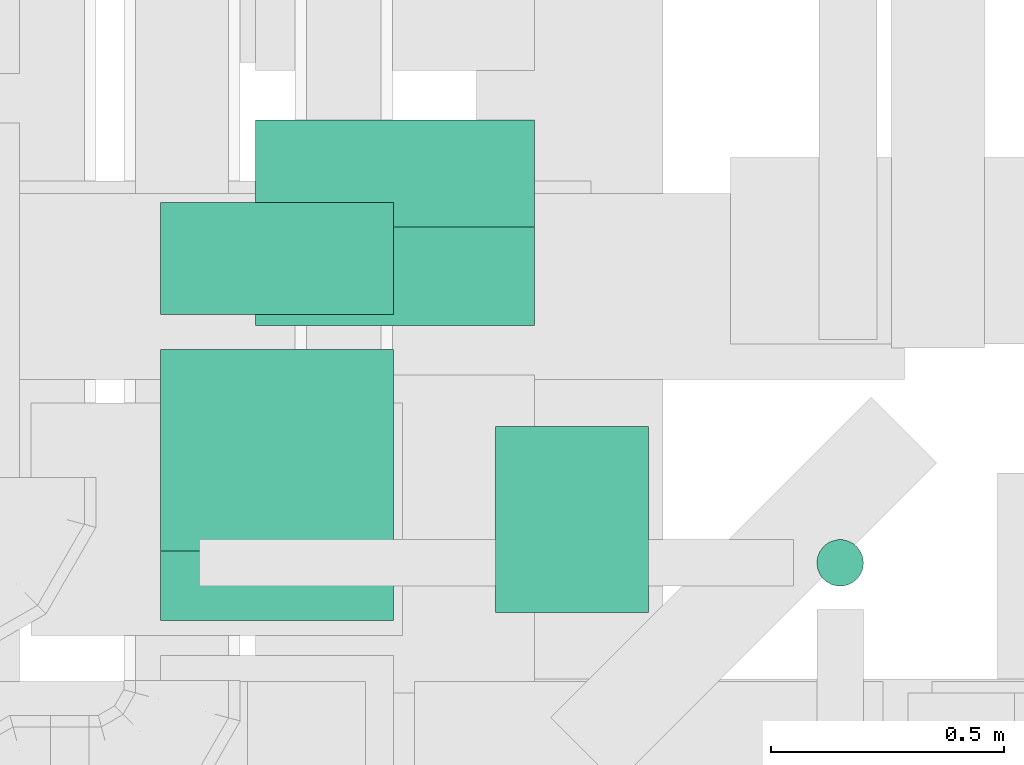
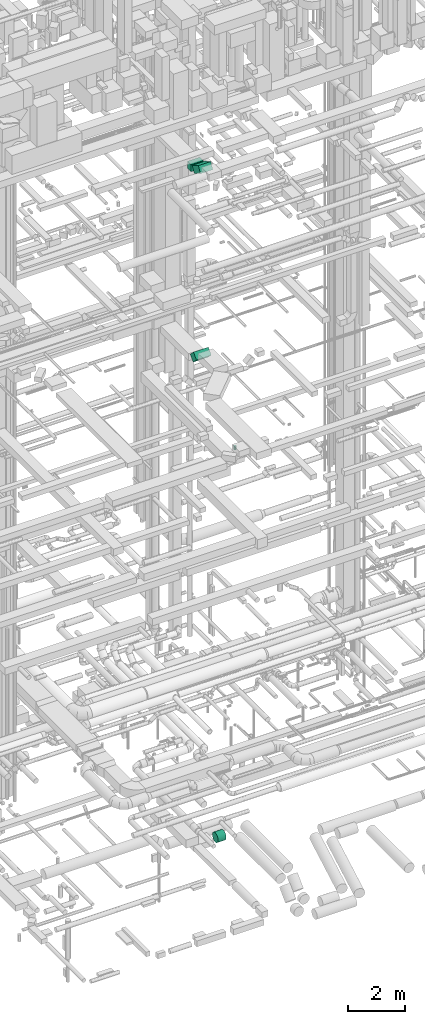
# One storey, part 168 of 337: 5 flow segments.
"""IFC2X3 building model written with IfcOpenShell, lengths in millimetres."""

import ifcopenshell
import ifcopenshell.guid

model = None  # the IFC model being written
_history = None  # IfcOwnerHistory: only IFC2X3 demands one
_inside = {}  # id of a spatial element -> (the spatial element, [elements in it])
_under = {}  # id of a project, library or spatial element -> (it, [spatial elements below it])
_declared = {}  # id of a project -> (the project, [libraries it declares])
_typed = {}  # id of a type object -> (the type object, [elements of that type])
_made_of = {}  # id of a material, layer set ... -> (it, [elements and type objects made of it])


def new_model(schema):
    """Start an empty IFC model of exactly this schema.

    Asked for "IFC4X3", IfcOpenShell would pick the latest addendum, in which some entities
    have other attributes; the version numbers below select the first issue.
    IFC2X3 requires an IfcOwnerHistory on every rooted entity: one is made here for all.
    """
    global model, _history
    if schema == "IFC4X3":
        model = ifcopenshell.file(schema_version=(4, 3, 0, 0))
    else:
        model = ifcopenshell.file(schema=schema)
    _inside.clear()
    _under.clear()
    _declared.clear()
    _typed.clear()
    _made_of.clear()
    _history = None
    if model.schema == "IFC2X3":
        org = make("IfcOrganization", Name="unknown")
        user = make(
            "IfcPersonAndOrganization",
            ThePerson=make("IfcPerson", FamilyName="unknown"),
            TheOrganization=org,
        )
        app = make(
            "IfcApplication",
            ApplicationDeveloper=org,
            Version="unknown",
            ApplicationFullName="unknown",
            ApplicationIdentifier="unknown",
        )
        _history = make(
            "IfcOwnerHistory",
            OwningUser=user,
            OwningApplication=app,
            ChangeAction="ADDED",
            CreationDate=0,
        )
    return model


def make(cls, **values):
    """One entity of the class cls with the attributes given. An attribute that is None is left unset."""
    return model.create_entity(
        cls, **{name: value for name, value in values.items() if value is not None}
    )


def entity(cls, *values):
    """Any entity or typed value of the class cls, its attributes in the order of the schema. None: left unset."""
    e = model.create_entity(cls)
    for i, value in enumerate(values):
        if value is not None:
            e[i] = value
    return e


def rooted(cls, **values):
    """An entity with a GlobalId (a new one), such as an element, a storey or a relation."""
    return make(cls, GlobalId=ifcopenshell.guid.new(), OwnerHistory=_history, **values)


def si_unit(unit_type, name, prefix=None):
    """IfcSIUnit, for example si_unit("LENGTHUNIT", "METRE", prefix="MILLI")."""
    return make("IfcSIUnit", UnitType=unit_type, Prefix=prefix, Name=name)


def converted_unit(unit_type, name, factor, base, dimensions=None, offset=None):
    """IfcConversionBasedUnit, such as the inch: factor (a typed value) times the base unit."""
    return make(
        "IfcConversionBasedUnit"
        if offset is None
        else "IfcConversionBasedUnitWithOffset",
        ConversionOffset=offset,
        Dimensions=None
        if dimensions is None
        else entity("IfcDimensionalExponents", *dimensions),
        UnitType=unit_type,
        Name=name,
        ConversionFactor=make(
            "IfcMeasureWithUnit", ValueComponent=factor, UnitComponent=base
        ),
    )


def derived_unit(unit_type, elements):
    """IfcDerivedUnit: a product of units, each with its exponent."""
    return make(
        "IfcDerivedUnit",
        Elements=[
            make("IfcDerivedUnitElement", Unit=unit, Exponent=power)
            for unit, power in elements
        ],
        UnitType=unit_type,
    )


def assignment(units):
    """IfcUnitAssignment: the units of a project."""
    return None if units is None else make("IfcUnitAssignment", Units=units)


def point(xyz):
    """IfcCartesianPoint."""
    return None if xyz is None else make("IfcCartesianPoint", Coordinates=xyz)


def direction(xyz):
    """IfcDirection."""
    return None if xyz is None else make("IfcDirection", DirectionRatios=xyz)


def frame(location, z_axis=None, x_axis=None):
    """IfcAxis2Placement3D, a coordinate frame: its origin and axes. An axis left out is left unset."""
    return make(
        "IfcAxis2Placement3D",
        Location=point(location),
        Axis=direction(z_axis),
        RefDirection=direction(x_axis),
    )


def frame_2d(location, x_axis=None):
    """IfcAxis2Placement2D, a coordinate frame in the plane: its origin and x axis."""
    return make(
        "IfcAxis2Placement2D", Location=point(location), RefDirection=direction(x_axis)
    )


def origin():
    """The frame at (0, 0, 0) with its axes left unset."""
    return frame((0.0, 0.0, 0.0))


def origin_2d_with_axis():
    """The frame at (0, 0) in the plane with the x axis (1, 0) written out."""
    return frame_2d((0.0, 0.0), x_axis=(1.0, 0.0))


def place(relative_to, where):
    """IfcLocalPlacement: puts the frame where relative to a parent placement (None: the world)."""
    return make(
        "IfcLocalPlacement", PlacementRelTo=relative_to, RelativePlacement=where
    )


def context(
    kind, dimensions, precision=None, world=None, true_north=None, identifier=None
):
    """IfcGeometricRepresentationContext, for example the 3D "Model" context."""
    return make(
        "IfcGeometricRepresentationContext",
        ContextIdentifier=identifier,
        ContextType=kind,
        CoordinateSpaceDimension=dimensions,
        Precision=precision,
        WorldCoordinateSystem=world,
        TrueNorth=true_north,
    )


def subcontext(parent, identifier, kind, view, scale=None):
    """IfcGeometricRepresentationSubContext, for example "Body" below "Model"."""
    return make(
        "IfcGeometricRepresentationSubContext",
        ContextIdentifier=identifier,
        ContextType=kind,
        ParentContext=parent,
        TargetScale=scale,
        TargetView=view,
    )


def project(units=None, contexts=None):
    """IfcProject with its units and contexts."""
    return rooted(
        "IfcProject",
        Name="project",
        RepresentationContexts=contexts,
        UnitsInContext=assignment(units),
    )


def spatial(cls, under=None, at=None, **own):
    """A site, building, storey or space (cls), placed at a placement, below another one or the project."""
    s = rooted(cls, ObjectPlacement=at, **own)
    if under is not None:
        _under.setdefault(under.id(), (under, []))[1].append(s)
    return s


def profile(cls, at=None, kind="AREA", **sizes):
    """A parametric profile (cls). Its sizes go by their IFC names, for example OverallWidth=200.0."""
    return make(cls, ProfileType=kind, Position=at, **sizes)


def rectangle(**sizes):
    """IfcRectangleProfileDef."""
    return profile("IfcRectangleProfileDef", **sizes)


def circle(**sizes):
    """IfcCircleProfileDef."""
    return profile("IfcCircleProfileDef", **sizes)


def extrude(swept, where, along, depth):
    """IfcExtrudedAreaSolid: the profile swept, set in the frame where, extruded along a direction by depth."""
    return make(
        "IfcExtrudedAreaSolid",
        SweptArea=swept,
        Position=where,
        ExtrudedDirection=direction(along),
        Depth=depth,
    )


def shape(context_of_items, identifier, shape_type, items):
    """IfcShapeRepresentation: the items that make up one representation, for example the "Body"."""
    return make(
        "IfcShapeRepresentation",
        ContextOfItems=context_of_items,
        RepresentationIdentifier=identifier,
        RepresentationType=shape_type,
        Items=items,
    )


def made_of(thing, what):
    """Note that an element or type object is made of a material, layer set ...; save() writes the relation."""
    if what is not None:
        _made_of.setdefault(what.id(), (what, []))[1].append(thing)
    return thing


def type_object(cls, material=None, **own):
    """A type object (cls), such as IfcWallType, which elements share."""
    return made_of(rooted(cls, **own), material)


def element(
    cls,
    number,
    at=None,
    inside=None,
    cuts=None,
    type_object=None,
    material=None,
    context=None,
    identifier="Body",
    shape_type=None,
    held_by="IfcProductDefinitionShape",
    body=None,
    shapes=None,
    **own,
):
    """One element of the class cls, such as IfcWall. Its Tag is "e" and its number.

    at: its placement. inside: the storey or other place that contains it. cuts: it is an
    opening in that element (IfcRelVoidsElement). A single representation is given by context,
    identifier, shape_type and body (its items); several are given by shapes. held_by: the class
    of the entity that holds the representations. save() writes the other relations.
    """
    e = rooted(cls, Tag="e%d" % number, ObjectPlacement=at, **own)
    if body is not None:
        shapes = [shape(context, identifier, shape_type, body)]
    if shapes is not None:
        e.Representation = make(held_by, Representations=shapes)
    if inside is not None:
        _inside.setdefault(inside.id(), (inside, []))[1].append(e)
    if cuts is not None:
        rooted(
            "IfcRelVoidsElement", RelatingBuildingElement=cuts, RelatedOpeningElement=e
        )
    if type_object is not None:
        _typed.setdefault(type_object.id(), (type_object, []))[1].append(e)
    return made_of(e, material)


def aggregate(whole, parts):
    """IfcRelAggregates: a whole, such as a stair, and the parts it consists of."""
    return rooted("IfcRelAggregates", RelatingObject=whole, RelatedObjects=parts)


def save(model, path):
    """Write the relations noted so far, then the file.

    IfcRelAggregates (storeys below a building ...), IfcRelContainedInSpatialStructure (elements
    in a storey), IfcRelDefinesByType, IfcRelAssociatesMaterial and IfcRelDeclares: one each for
    every whole, place, type object, material and project.
    """
    for whole, parts in _under.values():
        aggregate(whole, parts)
    for where, things in _inside.values():
        rooted(
            "IfcRelContainedInSpatialStructure",
            RelatedElements=things,
            RelatingStructure=where,
        )
    for kind, things in _typed.values():
        rooted("IfcRelDefinesByType", RelatedObjects=things, RelatingType=kind)
    for what, things in _made_of.values():
        rooted("IfcRelAssociatesMaterial", RelatedObjects=things, RelatingMaterial=what)
    for by, libraries in _declared.values():
        rooted("IfcRelDeclares", RelatingContext=by, RelatedDefinitions=libraries)
    model.write(path)


model = new_model("IFC2X3")

# Units and contexts
model_context = context("Model", 3, precision=0.01, world=origin(), true_north=direction((6.12303176911189e-17, 1.0)))
body_context = subcontext(model_context, "Body", "Model", "MODEL_VIEW")
ifc_project = project(units=[si_unit("LENGTHUNIT", "METRE", prefix="MILLI"), si_unit("AREAUNIT", "SQUARE_METRE"), si_unit("VOLUMEUNIT", "CUBIC_METRE"), converted_unit("PLANEANGLEUNIT", "DEGREE", entity("IfcRatioMeasure", 0.0174532925199433), si_unit("PLANEANGLEUNIT", "RADIAN"), dimensions=[0, 0, 0, 0, 0, 0, 0]), si_unit("MASSUNIT", "GRAM", prefix="KILO"), derived_unit("MASSDENSITYUNIT", [(si_unit("MASSUNIT", "GRAM", prefix="KILO"), 1), (si_unit("LENGTHUNIT", "METRE"), -3)]), derived_unit("MOMENTOFINERTIAUNIT", [(si_unit("LENGTHUNIT", "METRE"), 4)]), si_unit("TIMEUNIT", "SECOND"), si_unit("FREQUENCYUNIT", "HERTZ"), si_unit("THERMODYNAMICTEMPERATUREUNIT", "DEGREE_CELSIUS"), derived_unit("THERMALTRANSMITTANCEUNIT", [(si_unit("MASSUNIT", "GRAM", prefix="KILO"), 1), (si_unit("THERMODYNAMICTEMPERATUREUNIT", "KELVIN"), -1), (si_unit("TIMEUNIT", "SECOND"), -3)]), derived_unit("VOLUMETRICFLOWRATEUNIT", [(si_unit("LENGTHUNIT", "METRE"), 3), (si_unit("TIMEUNIT", "SECOND"), -1)]), derived_unit("MASSFLOWRATEUNIT", [(si_unit("MASSUNIT", "GRAM", prefix="KILO"), 1), (si_unit("TIMEUNIT", "SECOND"), -1)]), derived_unit("ROTATIONALFREQUENCYUNIT", [(si_unit("TIMEUNIT", "SECOND"), -1)]), si_unit("ELECTRICCURRENTUNIT", "AMPERE"), si_unit("ELECTRICVOLTAGEUNIT", "VOLT"), si_unit("POWERUNIT", "WATT"), si_unit("FORCEUNIT", "NEWTON", prefix="KILO"), si_unit("ILLUMINANCEUNIT", "LUX"), si_unit("LUMINOUSFLUXUNIT", "LUMEN"), si_unit("LUMINOUSINTENSITYUNIT", "CANDELA"), derived_unit("USERDEFINED", [(si_unit("MASSUNIT", "GRAM", prefix="KILO"), -1), (si_unit("LENGTHUNIT", "METRE"), -2), (si_unit("TIMEUNIT", "SECOND"), 3), (si_unit("LUMINOUSFLUXUNIT", "LUMEN"), 1)]), derived_unit("LINEARVELOCITYUNIT", [(si_unit("LENGTHUNIT", "METRE"), 1), (si_unit("TIMEUNIT", "SECOND"), -1)]), si_unit("PRESSUREUNIT", "PASCAL"), derived_unit("USERDEFINED", [(si_unit("LENGTHUNIT", "METRE"), -2), (si_unit("MASSUNIT", "GRAM", prefix="KILO"), 1), (si_unit("TIMEUNIT", "SECOND"), -2)]), derived_unit("LINEARFORCEUNIT", [(si_unit("MASSUNIT", "GRAM", prefix="KILO"), 1), (si_unit("LENGTHUNIT", "METRE"), 1), (si_unit("TIMEUNIT", "SECOND"), -2), (si_unit("LENGTHUNIT", "METRE"), -1)]), derived_unit("PLANARFORCEUNIT", [(si_unit("MASSUNIT", "GRAM", prefix="KILO"), 1), (si_unit("LENGTHUNIT", "METRE"), 1), (si_unit("TIMEUNIT", "SECOND"), -2), (si_unit("LENGTHUNIT", "METRE"), -2)])], contexts=[model_context])

# Site, building, storey
site_placement = place(None, origin())
site = spatial("IfcSite", under=ifc_project, at=site_placement, CompositionType="ELEMENT")
building_placement = place(site_placement, origin())
building = spatial("IfcBuilding", under=site, at=building_placement, CompositionType="ELEMENT")
storey_placement = place(building_placement, origin())
storey = spatial("IfcBuildingStorey", under=building, at=storey_placement, CompositionType="ELEMENT", Elevation=0.0)

# Flow segments
duct_segment_type_1 = type_object("IfcDuctSegmentType", PredefinedType="NOTDEFINED")
flow_segment_1_placement = place(storey_placement, frame((50220.03, 6639.4, 18751.8)))
element("IfcFlowSegment", 1, at=flow_segment_1_placement, inside=storey, type_object=duct_segment_type_1, context=body_context, shape_type="SweptSolid", body=[
    extrude(rectangle(XDim=324.228355337257, YDim=300.0, at=origin_2d_with_axis()), frame((0.0, 220.7, 220.7), z_axis=(1.0, 0.0, 0.0), x_axis=(0.0, 0.707106781186507, -0.707106781186588)), (0.0, 0.0, 1.0), 600.000000000002),
])
flow_segment_2_placement = place(storey_placement, frame((50016.44, 6663.13, 27070.0)))
element("IfcFlowSegment", 2, at=flow_segment_2_placement, inside=storey, type_object=duct_segment_type_1, context=body_context, shape_type="SweptSolid", body=[
    extrude(rectangle(XDim=241.061839590509, YDim=499.999999999999, at=origin_2d_with_axis()), frame((250.0, 120.53, 0.0), z_axis=(0.0, 0.0, 1.0), x_axis=(0.0, -1.0, 0.0)), (0.0, 0.0, 1.0), 300.000000000001),
])
flow_segment_3_placement = place(storey_placement, frame((50016.44, 6005.79, 27130.29)))
element("IfcFlowSegment", 3, at=flow_segment_3_placement, inside=storey, type_object=duct_segment_type_1, context=body_context, shape_type="SweptSolid", body=[
    extrude(rectangle(XDim=300.000000000002, YDim=499.230484541356, at=frame_2d((0.0, 0.0), x_axis=(0.0, 1.0))), frame((0.0, 291.17, 254.71), z_axis=(1.0, 0.0, 0.0), x_axis=(0.0, -0.86602540378444, 0.499999999999998)), (0.0, 0.0, 1.0), 500.000000000008),
])
duct_segment_type_2 = type_object("IfcDuctSegmentType", PredefinedType="NOTDEFINED")
flow_segment_4_placement = place(storey_placement, frame((50735.84, 6021.95, -1501.6)))
element("IfcFlowSegment", 4, at=flow_segment_4_placement, inside=storey, type_object=duct_segment_type_2, context=body_context, shape_type="SweptSolid", body=[
    extrude(circle(Radius=200.0, at=origin_2d_with_axis()), frame((0.0, 201.6, 201.6), z_axis=(1.0, 0.0, 0.0), x_axis=(0.0, -1.0, 0.0)), (0.0, 0.0, 1.0), 328.315702253713),
])
flow_segment_5_placement = place(storey_placement, frame((51424.41, 6078.27, 15050.0)))
element("IfcFlowSegment", 5, at=flow_segment_5_placement, inside=storey, type_object=duct_segment_type_2, context=body_context, shape_type="SweptSolid", body=[
    extrude(circle(Radius=50.0, at=origin_2d_with_axis()), frame((51.6, 51.6, 0.0), z_axis=(0.0, 0.0, 1.0), x_axis=(-1.0, 0.0, 0.0)), (0.0, 0.0, 1.0), 150.000041586241),
])

save(model, "model.ifc")
